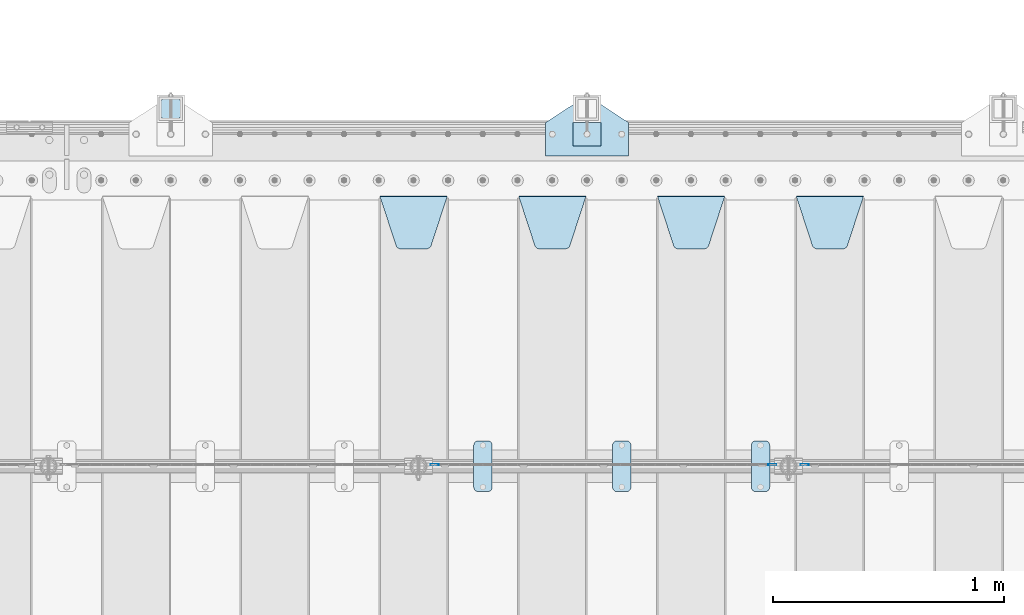
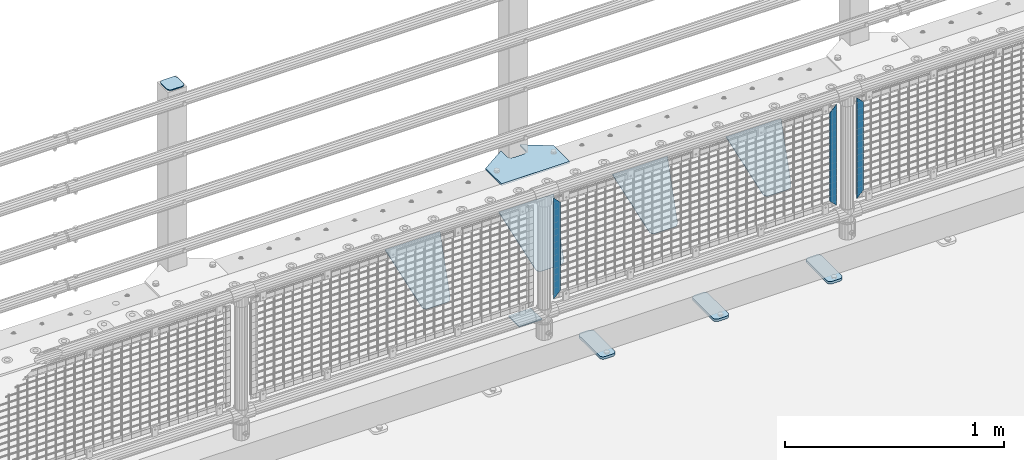
# One storey, part 217 of 247: 13 plates.
"""IFC2X3 building model written with IfcOpenShell, lengths in millimetres."""

from ifc_helpers import new_model, si_unit, frame, origin_with_axes, place, context, subcontext, project, spatial, faceted_brep, material, type_object, element, save


model = new_model("IFC2X3")

# Units and contexts
model_context = context("Model", 3, precision=1e-05, world=origin_with_axes())
body_context = subcontext(model_context, "Body", "Model", "MODEL_VIEW")
ifc_project = project(units=[si_unit("LENGTHUNIT", "METRE", prefix="MILLI"), si_unit("AREAUNIT", "SQUARE_METRE"), si_unit("VOLUMEUNIT", "CUBIC_METRE"), si_unit("MASSUNIT", "GRAM", prefix="KILO"), si_unit("TIMEUNIT", "SECOND"), si_unit("PLANEANGLEUNIT", "RADIAN"), si_unit("SOLIDANGLEUNIT", "STERADIAN"), si_unit("THERMODYNAMICTEMPERATUREUNIT", "DEGREE_CELSIUS"), si_unit("LUMINOUSINTENSITYUNIT", "LUMEN")], contexts=[model_context])

# Site, building, storey
site_placement = place(None, origin_with_axes())
site = spatial("IfcSite", under=ifc_project, at=site_placement, CompositionType="ELEMENT")
building_placement = place(site_placement, origin_with_axes())
building = spatial("IfcBuilding", under=site, at=building_placement, Name="Standard", CompositionType="ELEMENT")
storey_placement = place(building_placement, origin_with_axes())
storey = spatial("IfcBuildingStorey", under=building, at=storey_placement, Name="Undefined", CompositionType="ELEMENT", Elevation=0.0)

# Plates
ifc_material_1 = material(Name="STEEL/S355J2")
plate_type_1 = type_object("IfcPlateType", PredefinedType="NOTDEFINED")
plate_1_placement = place(storey_placement, frame((8460.0, 7774.5, 21.0199999999977), z_axis=(1.0, 0.0, 0.0), x_axis=(0.0, -0.999999999999548, -9.5100000000016e-07)))
element("IfcPlate", 1, at=plate_1_placement, inside=storey, type_object=plate_type_1, material=ifc_material_1, context=body_context, shape_type="Brep", body=[
    faceted_brep([(0.0, -7.0, 20.0), (0.0, -7.0, 60.0), (0.0, 7.0, 60.0), (0.0, 7.0, 20.0), (0.384294391935327, -7.0, 63.9018064403226), (0.384294391935327, 7.0, 63.9018064403226), (1.52240934977453, -7.0, 67.6536686473009), (1.52240934977453, 7.0, 67.6536686473009), (3.37060775394912, -7.0, 71.1114046603925), (3.37060775394912, 7.0, 71.1114046603925), (5.85786437626939, -7.0, 74.1421356237315), (5.85786437626939, 7.0, 74.1421356237315), (8.8885953396084, -7.0, 76.6293922460518), (8.8885953396084, 7.0, 76.6293922460518), (12.3463313526981, -7.0, 78.4775906502255), (12.3463313526981, 7.0, 78.4775906502255), (16.0981935596774, -7.0, 79.6157056080647), (16.0981935596774, 7.0, 79.6157056080647), (20.0, -7.0, 80.0), (20.0, 7.0, 80.0), (200.0, -7.0, 80.0), (200.0, 7.0, 80.0), (203.901806440323, -7.0, 79.6157056080647), (203.901806440323, 7.0, 79.6157056080647), (207.653668647302, -7.0, 78.4775906502255), (207.653668647302, 7.0, 78.4775906502255), (211.111404660392, -7.0, 76.6293922460518), (211.111404660392, 7.0, 76.6293922460518), (214.142135623731, -7.0, 74.1421356237315), (214.142135623731, 7.0, 74.1421356237315), (216.629392246051, -7.0, 71.1114046603925), (216.629392246051, 7.0, 71.1114046603925), (218.477590650225, -7.0, 67.6536686473009), (218.477590650225, 7.0, 67.6536686473009), (219.615705608065, -7.0, 63.9018064403226), (219.615705608065, 7.0, 63.9018064403226), (220.0, -7.0, 60.0), (220.0, 7.0, 60.0), (220.0, -7.0, 20.0), (220.0, 7.0, 20.0), (219.615705608065, -7.0, 16.0981935596774), (219.615705608065, 7.0, 16.0981935596774), (218.477590650225, -7.0, 12.3463313526991), (218.477590650225, 7.0, 12.3463313526991), (216.629392246051, -7.0, 8.88859533960749), (216.629392246051, 7.0, 8.88859533960749), (214.142135623731, -7.0, 5.85786437626848), (214.142135623731, 7.0, 5.85786437626848), (211.111404660392, -7.0, 3.37060775394821), (211.111404660392, 7.0, 3.37060775394821), (207.653668647302, -7.0, 1.52240934977453), (207.653668647302, 7.0, 1.52240934977453), (203.901806440323, -7.0, 0.384294391935327), (203.901806440323, 7.0, 0.384294391935327), (200.0, -7.0, 0.0), (200.0, 7.0, 0.0), (20.0, -7.0, 0.0), (20.0, 7.0, 0.0), (16.0981935596774, -7.0, 0.384294391935327), (16.0981935596774, 7.0, 0.384294391935327), (12.3463313526981, -7.0, 1.52240934977453), (12.3463313526981, 7.0, 1.52240934977453), (8.8885953396084, -7.0, 3.37060775394821), (8.8885953396084, 7.0, 3.37060775394821), (5.85786437626939, -7.0, 5.85786437626848), (5.85786437626939, 7.0, 5.85786437626848), (3.37060775394912, -7.0, 8.88859533960749), (3.37060775394912, 7.0, 8.88859533960749), (1.52240934977453, -7.0, 12.3463313526991), (1.52240934977453, 7.0, 12.3463313526991), (0.384294391935327, -7.0, 16.0981935596774), (0.384294391935327, 7.0, 16.0981935596774)], [[[0, 1, 2, 3]], [[1, 4, 5, 2]], [[4, 6, 7, 5]], [[6, 8, 9, 7]], [[8, 10, 11, 9]], [[10, 12, 13, 11]], [[12, 14, 15, 13]], [[14, 16, 17, 15]], [[16, 18, 19, 17]], [[18, 20, 21, 19]], [[20, 22, 23, 21]], [[22, 24, 25, 23]], [[24, 26, 27, 25]], [[26, 28, 29, 27]], [[28, 30, 31, 29]], [[30, 32, 33, 31]], [[32, 34, 35, 33]], [[34, 36, 37, 35]], [[36, 38, 39, 37]], [[38, 40, 41, 39]], [[40, 42, 43, 41]], [[42, 44, 45, 43]], [[44, 46, 47, 45]], [[46, 48, 49, 47]], [[48, 50, 51, 49]], [[50, 52, 53, 51]], [[52, 54, 55, 53]], [[54, 56, 57, 55]], [[56, 58, 59, 57]], [[58, 60, 61, 59]], [[60, 62, 63, 61]], [[62, 64, 65, 63]], [[64, 66, 67, 65]], [[66, 68, 69, 67]], [[68, 70, 71, 69]], [[70, 0, 3, 71]], [[5, 7, 9, 11, 13, 15, 17, 19, 21, 23, 25, 27, 29, 31, 33, 35, 37, 39, 41, 43, 45, 47, 49, 51, 53, 55, 57, 59, 61, 63, 65, 67, 69, 71, 3, 2]], [[70, 68, 66, 64, 62, 60, 58, 56, 54, 52, 50, 48, 46, 44, 42, 40, 38, 36, 34, 32, 30, 28, 26, 24, 22, 20, 18, 16, 14, 12, 10, 8, 6, 4, 1, 0]]]),
])
plate_2_placement = place(storey_placement, frame((7860.0, 7774.5, 21.0199999999977), z_axis=(1.0, 0.0, 0.0), x_axis=(0.0, -0.999999999999548, -9.5100000000016e-07)))
element("IfcPlate", 2, at=plate_2_placement, inside=storey, type_object=plate_type_1, material=ifc_material_1, context=body_context, shape_type="Brep", body=[
    faceted_brep([(0.0, -7.0, 20.0), (0.0, -7.0, 60.0), (0.0, 7.0, 60.0), (0.0, 7.0, 20.0), (0.384294391935327, -7.0, 63.9018064403226), (0.384294391935327, 7.0, 63.9018064403226), (1.52240934977453, -7.0, 67.6536686473009), (1.52240934977453, 7.0, 67.6536686473009), (3.37060775394912, -7.0, 71.1114046603925), (3.37060775394912, 7.0, 71.1114046603925), (5.85786437626939, -7.0, 74.1421356237315), (5.85786437626939, 7.0, 74.1421356237315), (8.8885953396084, -7.0, 76.6293922460518), (8.8885953396084, 7.0, 76.6293922460518), (12.3463313526981, -7.0, 78.4775906502255), (12.3463313526981, 7.0, 78.4775906502255), (16.0981935596774, -7.0, 79.6157056080647), (16.0981935596774, 7.0, 79.6157056080647), (20.0, -7.0, 80.0), (20.0, 7.0, 80.0), (200.0, -7.0, 80.0), (200.0, 7.0, 80.0), (203.901806440323, -7.0, 79.6157056080647), (203.901806440323, 7.0, 79.6157056080647), (207.653668647302, -7.0, 78.4775906502255), (207.653668647302, 7.0, 78.4775906502255), (211.111404660392, -7.0, 76.6293922460518), (211.111404660392, 7.0, 76.6293922460518), (214.142135623731, -7.0, 74.1421356237315), (214.142135623731, 7.0, 74.1421356237315), (216.629392246051, -7.0, 71.1114046603925), (216.629392246051, 7.0, 71.1114046603925), (218.477590650225, -7.0, 67.6536686473009), (218.477590650225, 7.0, 67.6536686473009), (219.615705608065, -7.0, 63.9018064403226), (219.615705608065, 7.0, 63.9018064403226), (220.0, -7.0, 60.0), (220.0, 7.0, 60.0), (220.0, -7.0, 20.0), (220.0, 7.0, 20.0), (219.615705608065, -7.0, 16.0981935596774), (219.615705608065, 7.0, 16.0981935596774), (218.477590650225, -7.0, 12.3463313526991), (218.477590650225, 7.0, 12.3463313526991), (216.629392246051, -7.0, 8.88859533960749), (216.629392246051, 7.0, 8.88859533960749), (214.142135623731, -7.0, 5.85786437626848), (214.142135623731, 7.0, 5.85786437626848), (211.111404660392, -7.0, 3.37060775394821), (211.111404660392, 7.0, 3.37060775394821), (207.653668647302, -7.0, 1.52240934977453), (207.653668647302, 7.0, 1.52240934977453), (203.901806440323, -7.0, 0.384294391935327), (203.901806440323, 7.0, 0.384294391935327), (200.0, -7.0, 0.0), (200.0, 7.0, 0.0), (20.0, -7.0, 0.0), (20.0, 7.0, 0.0), (16.0981935596774, -7.0, 0.384294391935327), (16.0981935596774, 7.0, 0.384294391935327), (12.3463313526981, -7.0, 1.52240934977453), (12.3463313526981, 7.0, 1.52240934977453), (8.8885953396084, -7.0, 3.37060775394821), (8.8885953396084, 7.0, 3.37060775394821), (5.85786437626939, -7.0, 5.85786437626848), (5.85786437626939, 7.0, 5.85786437626848), (3.37060775394912, -7.0, 8.88859533960749), (3.37060775394912, 7.0, 8.88859533960749), (1.52240934977453, -7.0, 12.3463313526991), (1.52240934977453, 7.0, 12.3463313526991), (0.384294391935327, -7.0, 16.0981935596774), (0.384294391935327, 7.0, 16.0981935596774)], [[[0, 1, 2, 3]], [[1, 4, 5, 2]], [[4, 6, 7, 5]], [[6, 8, 9, 7]], [[8, 10, 11, 9]], [[10, 12, 13, 11]], [[12, 14, 15, 13]], [[14, 16, 17, 15]], [[16, 18, 19, 17]], [[18, 20, 21, 19]], [[20, 22, 23, 21]], [[22, 24, 25, 23]], [[24, 26, 27, 25]], [[26, 28, 29, 27]], [[28, 30, 31, 29]], [[30, 32, 33, 31]], [[32, 34, 35, 33]], [[34, 36, 37, 35]], [[36, 38, 39, 37]], [[38, 40, 41, 39]], [[40, 42, 43, 41]], [[42, 44, 45, 43]], [[44, 46, 47, 45]], [[46, 48, 49, 47]], [[48, 50, 51, 49]], [[50, 52, 53, 51]], [[52, 54, 55, 53]], [[54, 56, 57, 55]], [[56, 58, 59, 57]], [[58, 60, 61, 59]], [[60, 62, 63, 61]], [[62, 64, 65, 63]], [[64, 66, 67, 65]], [[66, 68, 69, 67]], [[68, 70, 71, 69]], [[70, 0, 3, 71]], [[5, 7, 9, 11, 13, 15, 17, 19, 21, 23, 25, 27, 29, 31, 33, 35, 37, 39, 41, 43, 45, 47, 49, 51, 53, 55, 57, 59, 61, 63, 65, 67, 69, 71, 3, 2]], [[70, 68, 66, 64, 62, 60, 58, 56, 54, 52, 50, 48, 46, 44, 42, 40, 38, 36, 34, 32, 30, 28, 26, 24, 22, 20, 18, 16, 14, 12, 10, 8, 6, 4, 1, 0]]]),
])
plate_3_placement = place(storey_placement, frame((7260.0, 7774.5, 21.0199999999977), z_axis=(1.0, 0.0, 0.0), x_axis=(0.0, -0.999999999999548, -9.5100000000016e-07)))
element("IfcPlate", 3, at=plate_3_placement, inside=storey, type_object=plate_type_1, material=ifc_material_1, context=body_context, shape_type="Brep", body=[
    faceted_brep([(0.0, -7.0, 20.0), (0.0, -7.0, 60.0), (0.0, 7.0, 60.0), (0.0, 7.0, 20.0), (0.384294391935327, -7.0, 63.9018064403226), (0.384294391935327, 7.0, 63.9018064403226), (1.52240934977453, -7.0, 67.6536686473009), (1.52240934977453, 7.0, 67.6536686473009), (3.37060775394912, -7.0, 71.1114046603925), (3.37060775394912, 7.0, 71.1114046603925), (5.85786437626939, -7.0, 74.1421356237315), (5.85786437626939, 7.0, 74.1421356237315), (8.8885953396084, -7.0, 76.6293922460518), (8.8885953396084, 7.0, 76.6293922460518), (12.3463313526981, -7.0, 78.4775906502255), (12.3463313526981, 7.0, 78.4775906502255), (16.0981935596774, -7.0, 79.6157056080647), (16.0981935596774, 7.0, 79.6157056080647), (20.0, -7.0, 80.0), (20.0, 7.0, 80.0), (200.0, -7.0, 80.0), (200.0, 7.0, 80.0), (203.901806440323, -7.0, 79.6157056080647), (203.901806440323, 7.0, 79.6157056080647), (207.653668647302, -7.0, 78.4775906502255), (207.653668647302, 7.0, 78.4775906502255), (211.111404660392, -7.0, 76.6293922460518), (211.111404660392, 7.0, 76.6293922460518), (214.142135623731, -7.0, 74.1421356237315), (214.142135623731, 7.0, 74.1421356237315), (216.629392246051, -7.0, 71.1114046603925), (216.629392246051, 7.0, 71.1114046603925), (218.477590650225, -7.0, 67.6536686473009), (218.477590650225, 7.0, 67.6536686473009), (219.615705608065, -7.0, 63.9018064403226), (219.615705608065, 7.0, 63.9018064403226), (220.0, -7.0, 60.0), (220.0, 7.0, 60.0), (220.0, -7.0, 20.0), (220.0, 7.0, 20.0), (219.615705608065, -7.0, 16.0981935596774), (219.615705608065, 7.0, 16.0981935596774), (218.477590650225, -7.0, 12.3463313526991), (218.477590650225, 7.0, 12.3463313526991), (216.629392246051, -7.0, 8.88859533960749), (216.629392246051, 7.0, 8.88859533960749), (214.142135623731, -7.0, 5.85786437626848), (214.142135623731, 7.0, 5.85786437626848), (211.111404660392, -7.0, 3.37060775394821), (211.111404660392, 7.0, 3.37060775394821), (207.653668647302, -7.0, 1.52240934977453), (207.653668647302, 7.0, 1.52240934977453), (203.901806440323, -7.0, 0.384294391935327), (203.901806440323, 7.0, 0.384294391935327), (200.0, -7.0, 0.0), (200.0, 7.0, 0.0), (20.0, -7.0, 0.0), (20.0, 7.0, 0.0), (16.0981935596774, -7.0, 0.384294391935327), (16.0981935596774, 7.0, 0.384294391935327), (12.3463313526981, -7.0, 1.52240934977453), (12.3463313526981, 7.0, 1.52240934977453), (8.8885953396084, -7.0, 3.37060775394821), (8.8885953396084, 7.0, 3.37060775394821), (5.85786437626939, -7.0, 5.85786437626848), (5.85786437626939, 7.0, 5.85786437626848), (3.37060775394912, -7.0, 8.88859533960749), (3.37060775394912, 7.0, 8.88859533960749), (1.52240934977453, -7.0, 12.3463313526991), (1.52240934977453, 7.0, 12.3463313526991), (0.384294391935327, -7.0, 16.0981935596774), (0.384294391935327, 7.0, 16.0981935596774)], [[[0, 1, 2, 3]], [[1, 4, 5, 2]], [[4, 6, 7, 5]], [[6, 8, 9, 7]], [[8, 10, 11, 9]], [[10, 12, 13, 11]], [[12, 14, 15, 13]], [[14, 16, 17, 15]], [[16, 18, 19, 17]], [[18, 20, 21, 19]], [[20, 22, 23, 21]], [[22, 24, 25, 23]], [[24, 26, 27, 25]], [[26, 28, 29, 27]], [[28, 30, 31, 29]], [[30, 32, 33, 31]], [[32, 34, 35, 33]], [[34, 36, 37, 35]], [[36, 38, 39, 37]], [[38, 40, 41, 39]], [[40, 42, 43, 41]], [[42, 44, 45, 43]], [[44, 46, 47, 45]], [[46, 48, 49, 47]], [[48, 50, 51, 49]], [[50, 52, 53, 51]], [[52, 54, 55, 53]], [[54, 56, 57, 55]], [[56, 58, 59, 57]], [[58, 60, 61, 59]], [[60, 62, 63, 61]], [[62, 64, 65, 63]], [[64, 66, 67, 65]], [[66, 68, 69, 67]], [[68, 70, 71, 69]], [[70, 0, 3, 71]], [[5, 7, 9, 11, 13, 15, 17, 19, 21, 23, 25, 27, 29, 31, 33, 35, 37, 39, 41, 43, 45, 47, 49, 51, 53, 55, 57, 59, 61, 63, 65, 67, 69, 71, 3, 2]], [[70, 68, 66, 64, 62, 60, 58, 56, 54, 52, 50, 48, 46, 44, 42, 40, 38, 36, 34, 32, 30, 28, 26, 24, 22, 20, 18, 16, 14, 12, 10, 8, 6, 4, 1, 0]]]),
])
ifc_material_2 = material(Name="STEEL/S355N")
plate_type_2 = type_object("IfcPlateType", PredefinedType="NOTDEFINED")
plate_4_placement = place(storey_placement, frame((8655.0, 8831.76776695594, -1.767766952965), z_axis=(0.0, -0.707106781186548, -0.707106781186547), x_axis=(1.0, 0.0, 0.0)))
element("IfcPlate", 4, at=plate_4_placement, inside=storey, type_object=plate_type_2, material=ifc_material_2, context=body_context, shape_type="Brep", body=[
    faceted_brep([(0.0, -2.49999999999909, 0.0), (69.345504679477, -2.5, 300.17173142483), (69.345504679477, 2.50000000000091, 300.171731424831), (0.0, 2.5, -9.09494701772928e-13), (70.9274061199576, -2.5, 304.897442415399), (70.9274061199576, 2.50000000000091, 304.8974424154), (73.3818627772307, -2.49999999999909, 309.234538108527), (73.3818627772307, 2.5, 309.234538108526), (76.6187032999551, -2.5, 313.023683126102), (76.6187032999551, 2.50000000000091, 313.023683126102), (80.5190132704993, -2.49999999999909, 316.125672595371), (80.5190132704993, 2.50000000000091, 316.125672595372), (84.9395038596849, -2.49999999999909, 318.426546230476), (84.9395038596849, 2.5, 318.426546230475), (89.7177759439219, -2.5, 319.841774983274), (89.7177759439219, 2.50000000000091, 319.841774983275), (94.678286292652, -2.5, 320.319366455077), (94.678286292652, 2.50000000000091, 320.319366455077), (195.321713707348, -2.5, 320.319366455077), (195.321713707348, 2.50000000000091, 320.319366455077), (200.282224056078, -2.5, 319.841774983274), (200.282224056078, 2.50000000000091, 319.841774983275), (205.060496140315, -2.5, 318.426546230475), (205.060496140315, 2.5, 318.426546230474), (209.480986729501, -2.49999999999818, 316.12567259537), (209.480986729501, 2.50000000000091, 316.12567259537), (213.381296700045, -2.5, 313.023683126101), (213.381296700045, 2.50000000000091, 313.023683126101), (216.618137222769, -2.5, 309.234538108525), (216.618137222769, 2.5, 309.234538108525), (219.072593880042, -2.49999999999909, 304.897442415398), (219.072593880042, 2.5, 304.897442415398), (220.654495320523, -2.5, 300.17173142483), (220.654495320523, 2.50000000000091, 300.171731424831), (290.0, -2.49999999999909, 0.0), (290.0, 2.5, -9.09494701772928e-13)], [[[0, 1, 2, 3]], [[1, 4, 5, 2]], [[4, 6, 7, 5]], [[6, 8, 9, 7]], [[8, 10, 11, 9]], [[10, 12, 13, 11]], [[12, 14, 15, 13]], [[14, 16, 17, 15]], [[16, 18, 19, 17]], [[18, 20, 21, 19]], [[20, 22, 23, 21]], [[22, 24, 25, 23]], [[24, 26, 27, 25]], [[26, 28, 29, 27]], [[28, 30, 31, 29]], [[30, 32, 33, 31]], [[32, 34, 35, 33]], [[34, 0, 3, 35]], [[5, 7, 9, 11, 13, 15, 17, 19, 21, 23, 25, 27, 29, 31, 33, 35, 3, 2]], [[34, 32, 30, 28, 26, 24, 22, 20, 18, 16, 14, 12, 10, 8, 6, 4, 1, 0]]]),
])
plate_5_placement = place(storey_placement, frame((8055.0, 8831.76776695594, -1.767766952965), z_axis=(0.0, -0.707106781186548, -0.707106781186547), x_axis=(1.0, 0.0, 0.0)))
element("IfcPlate", 5, at=plate_5_placement, inside=storey, type_object=plate_type_2, material=ifc_material_2, context=body_context, shape_type="Brep", body=[
    faceted_brep([(0.0, -2.49999999999909, 0.0), (69.345504679477, -2.5, 300.17173142483), (69.345504679477, 2.50000000000091, 300.171731424831), (0.0, 2.5, -9.09494701772928e-13), (70.9274061199576, -2.5, 304.897442415399), (70.9274061199576, 2.50000000000091, 304.8974424154), (73.3818627772307, -2.49999999999909, 309.234538108527), (73.3818627772307, 2.5, 309.234538108526), (76.6187032999551, -2.5, 313.023683126102), (76.6187032999551, 2.50000000000091, 313.023683126102), (80.5190132704993, -2.49999999999909, 316.125672595371), (80.5190132704993, 2.50000000000091, 316.125672595372), (84.9395038596849, -2.49999999999909, 318.426546230476), (84.9395038596849, 2.5, 318.426546230475), (89.7177759439219, -2.5, 319.841774983274), (89.7177759439219, 2.50000000000091, 319.841774983275), (94.678286292652, -2.5, 320.319366455077), (94.678286292652, 2.50000000000091, 320.319366455077), (195.321713707348, -2.5, 320.319366455077), (195.321713707348, 2.50000000000091, 320.319366455077), (200.282224056078, -2.5, 319.841774983274), (200.282224056078, 2.50000000000091, 319.841774983275), (205.060496140315, -2.5, 318.426546230475), (205.060496140315, 2.5, 318.426546230474), (209.480986729501, -2.49999999999818, 316.12567259537), (209.480986729501, 2.50000000000091, 316.12567259537), (213.381296700045, -2.5, 313.023683126101), (213.381296700045, 2.50000000000091, 313.023683126101), (216.618137222769, -2.5, 309.234538108525), (216.618137222769, 2.5, 309.234538108525), (219.072593880042, -2.49999999999909, 304.897442415398), (219.072593880042, 2.5, 304.897442415398), (220.654495320523, -2.5, 300.17173142483), (220.654495320523, 2.50000000000091, 300.171731424831), (290.0, -2.49999999999909, 0.0), (290.0, 2.5, -9.09494701772928e-13)], [[[0, 1, 2, 3]], [[1, 4, 5, 2]], [[4, 6, 7, 5]], [[6, 8, 9, 7]], [[8, 10, 11, 9]], [[10, 12, 13, 11]], [[12, 14, 15, 13]], [[14, 16, 17, 15]], [[16, 18, 19, 17]], [[18, 20, 21, 19]], [[20, 22, 23, 21]], [[22, 24, 25, 23]], [[24, 26, 27, 25]], [[26, 28, 29, 27]], [[28, 30, 31, 29]], [[30, 32, 33, 31]], [[32, 34, 35, 33]], [[34, 0, 3, 35]], [[5, 7, 9, 11, 13, 15, 17, 19, 21, 23, 25, 27, 29, 31, 33, 35, 3, 2]], [[34, 32, 30, 28, 26, 24, 22, 20, 18, 16, 14, 12, 10, 8, 6, 4, 1, 0]]]),
])
plate_6_placement = place(storey_placement, frame((7455.0, 8831.76776695594, -1.767766952965), z_axis=(0.0, -0.707106781186548, -0.707106781186547), x_axis=(1.0, 0.0, 0.0)))
element("IfcPlate", 6, at=plate_6_placement, inside=storey, type_object=plate_type_2, material=ifc_material_2, context=body_context, shape_type="Brep", body=[
    faceted_brep([(0.0, -2.49999999999909, 0.0), (69.345504679477, -2.5, 300.17173142483), (69.345504679477, 2.50000000000091, 300.171731424831), (0.0, 2.5, -9.09494701772928e-13), (70.9274061199576, -2.5, 304.897442415399), (70.9274061199576, 2.50000000000091, 304.8974424154), (73.3818627772307, -2.49999999999909, 309.234538108527), (73.3818627772307, 2.5, 309.234538108526), (76.6187032999551, -2.5, 313.023683126102), (76.6187032999551, 2.50000000000091, 313.023683126102), (80.5190132704993, -2.49999999999909, 316.125672595371), (80.5190132704993, 2.50000000000091, 316.125672595372), (84.9395038596849, -2.49999999999909, 318.426546230476), (84.9395038596849, 2.5, 318.426546230475), (89.7177759439219, -2.5, 319.841774983274), (89.7177759439219, 2.50000000000091, 319.841774983275), (94.678286292652, -2.5, 320.319366455077), (94.678286292652, 2.50000000000091, 320.319366455077), (195.321713707348, -2.5, 320.319366455077), (195.321713707348, 2.50000000000091, 320.319366455077), (200.282224056078, -2.5, 319.841774983274), (200.282224056078, 2.50000000000091, 319.841774983275), (205.060496140315, -2.5, 318.426546230475), (205.060496140315, 2.5, 318.426546230474), (209.480986729501, -2.49999999999818, 316.12567259537), (209.480986729501, 2.50000000000091, 316.12567259537), (213.381296700045, -2.5, 313.023683126101), (213.381296700045, 2.50000000000091, 313.023683126101), (216.618137222769, -2.5, 309.234538108525), (216.618137222769, 2.5, 309.234538108525), (219.072593880042, -2.49999999999909, 304.897442415398), (219.072593880042, 2.5, 304.897442415398), (220.654495320523, -2.5, 300.17173142483), (220.654495320523, 2.50000000000091, 300.171731424831), (290.0, -2.49999999999909, 0.0), (290.0, 2.5, -9.09494701772928e-13)], [[[0, 1, 2, 3]], [[1, 4, 5, 2]], [[4, 6, 7, 5]], [[6, 8, 9, 7]], [[8, 10, 11, 9]], [[10, 12, 13, 11]], [[12, 14, 15, 13]], [[14, 16, 17, 15]], [[16, 18, 19, 17]], [[18, 20, 21, 19]], [[20, 22, 23, 21]], [[22, 24, 25, 23]], [[24, 26, 27, 25]], [[26, 28, 29, 27]], [[28, 30, 31, 29]], [[30, 32, 33, 31]], [[32, 34, 35, 33]], [[34, 0, 3, 35]], [[5, 7, 9, 11, 13, 15, 17, 19, 21, 23, 25, 27, 29, 31, 33, 35, 3, 2]], [[34, 32, 30, 28, 26, 24, 22, 20, 18, 16, 14, 12, 10, 8, 6, 4, 1, 0]]]),
])
plate_7_placement = place(storey_placement, frame((6855.0, 8831.76776695594, -1.767766952965), z_axis=(0.0, -0.707106781186548, -0.707106781186547), x_axis=(1.0, 0.0, 0.0)))
element("IfcPlate", 7, at=plate_7_placement, inside=storey, type_object=plate_type_2, material=ifc_material_2, context=body_context, shape_type="Brep", body=[
    faceted_brep([(0.0, -2.49999999999909, 0.0), (69.345504679477, -2.5, 300.17173142483), (69.345504679477, 2.50000000000091, 300.171731424831), (0.0, 2.5, -9.09494701772928e-13), (70.9274061199576, -2.5, 304.897442415399), (70.9274061199576, 2.50000000000091, 304.8974424154), (73.3818627772307, -2.49999999999909, 309.234538108527), (73.3818627772307, 2.5, 309.234538108526), (76.6187032999551, -2.5, 313.023683126102), (76.6187032999551, 2.50000000000091, 313.023683126102), (80.5190132704993, -2.49999999999909, 316.125672595371), (80.5190132704993, 2.50000000000091, 316.125672595372), (84.9395038596849, -2.49999999999909, 318.426546230476), (84.9395038596849, 2.5, 318.426546230475), (89.7177759439219, -2.5, 319.841774983274), (89.7177759439219, 2.50000000000091, 319.841774983275), (94.678286292652, -2.5, 320.319366455077), (94.678286292652, 2.50000000000091, 320.319366455077), (195.321713707348, -2.5, 320.319366455077), (195.321713707348, 2.50000000000091, 320.319366455077), (200.282224056078, -2.5, 319.841774983274), (200.282224056078, 2.50000000000091, 319.841774983275), (205.060496140315, -2.5, 318.426546230475), (205.060496140315, 2.5, 318.426546230474), (209.480986729501, -2.49999999999818, 316.12567259537), (209.480986729501, 2.50000000000091, 316.12567259537), (213.381296700045, -2.5, 313.023683126101), (213.381296700045, 2.50000000000091, 313.023683126101), (216.618137222769, -2.5, 309.234538108525), (216.618137222769, 2.5, 309.234538108525), (219.072593880042, -2.49999999999909, 304.897442415398), (219.072593880042, 2.5, 304.897442415398), (220.654495320523, -2.5, 300.17173142483), (220.654495320523, 2.50000000000091, 300.171731424831), (290.0, -2.49999999999909, 0.0), (290.0, 2.5, -9.09494701772928e-13)], [[[0, 1, 2, 3]], [[1, 4, 5, 2]], [[4, 6, 7, 5]], [[6, 8, 9, 7]], [[8, 10, 11, 9]], [[10, 12, 13, 11]], [[12, 14, 15, 13]], [[14, 16, 17, 15]], [[16, 18, 19, 17]], [[18, 20, 21, 19]], [[20, 22, 23, 21]], [[22, 24, 25, 23]], [[24, 26, 27, 25]], [[26, 28, 29, 27]], [[28, 30, 31, 29]], [[30, 32, 33, 31]], [[32, 34, 35, 33]], [[34, 0, 3, 35]], [[5, 7, 9, 11, 13, 15, 17, 19, 21, 23, 25, 27, 29, 31, 33, 35, 3, 2]], [[34, 32, 30, 28, 26, 24, 22, 20, 18, 16, 14, 12, 10, 8, 6, 4, 1, 0]]]),
])
ifc_material_3 = material(Name="Misc_Undefined")
plate_type_3 = type_object("IfcPlateType", PredefinedType="NOTDEFINED")
for number, where, z_axis, x_axis in (
    (8, (8709.50971354097, 7670.5, 879.519963133601), (-0.707008801899319, 0.0, -0.707204746899291), (-0.707204746899294, 0.0, 0.707008801899315)),
    (9, (7109.50971354097, 7670.5, 879.519963133601), (-0.707008801899319, 0.0, -0.707204746899291), (-0.707204746899294, 0.0, 0.707008801899315)),
):
    element("IfcPlate", number, at=place(storey_placement, frame(where, z_axis=z_axis, x_axis=x_axis)), inside=storey, type_object=plate_type_3, material=ifc_material_3, context=body_context, shape_type="Brep", body=[
        faceted_brep([(1.81898940354586e-12, -1.5, -5.6843418860808e-14), (-348.552185058596, -1.5, 348.655029296875), (-348.552185058596, 1.5, 348.655029296875), (1.81898940354586e-12, 1.5, -5.6843418860808e-14), (-348.544891357424, -1.5, 398.152496337891), (-348.544891357424, 1.5, 398.152496337891), (49.50439453125, -1.5, 7.6397554948926e-11), (49.50439453125, 1.5, 7.6397554948926e-11)], [[[0, 1, 2, 3]], [[1, 4, 5, 2]], [[4, 6, 7, 5]], [[6, 0, 3, 7]], [[5, 7, 3, 2]], [[6, 4, 1, 0]]]),
    ])
plate_8_placement = place(storey_placement, frame((8532.49968748361, 7670.5, 879.52), z_axis=(0.707103624179499, 0.0, -0.707109938179501), x_axis=(0.707109938179497, 0.0, 0.707103624179503)))
element("IfcPlate", 10, at=plate_8_placement, inside=storey, type_object=plate_type_3, material=ifc_material_3, context=body_context, shape_type="Brep", body=[
    faceted_brep([(1.81898940354586e-12, -1.5, -5.6843418860808e-14), (-348.605163574215, -1.5, 348.60208129883), (-348.605163574215, 1.5, 348.60208129883), (1.81898940354586e-12, 1.5, -5.6843418860808e-14), (-348.605163574215, -1.5, 398.099334716799), (-348.605163574215, 1.5, 398.099334716799), (49.4976959228497, -1.5, 7.09405867382884e-11), (49.4976959228497, 1.5, 7.09405867382884e-11)], [[[0, 1, 2, 3]], [[1, 4, 5, 2]], [[4, 6, 7, 5]], [[6, 0, 3, 7]], [[5, 7, 3, 2]], [[6, 4, 1, 0]]]),
])
plate_type_4 = type_object("IfcPlateType", PredefinedType="NOTDEFINED")
plate_9_placement = place(storey_placement, frame((7570.0, 9005.0, 5.00000000004911), z_axis=(0.0, 1.0, 0.0), x_axis=(1.0, 0.0, 0.0)))
element("IfcPlate", 11, at=plate_9_placement, inside=storey, type_object=plate_type_4, material=ifc_material_1, context=body_context, shape_type="Brep", body=[
    faceted_brep([(9.04219632502645e-09, -5.00000000143385, -2.89173840428703e-09), (2.31396552408114e-06, -5.0, 145.0), (2.31396552408114e-06, 5.0, 145.0), (7.66340235713869e-09, 4.99999999856618, -2.89173840428703e-09), (130.0, -5.0, 230.0), (130.0, 5.0, 230.0), (130.0, -5.0, 180.0), (130.0, 5.0, 180.0), (130.48036798992, -5.0, 175.122741949597), (130.48036798992, 5.0, 175.122741949597), (131.903011687218, -5.0, 170.432914190873), (131.903011687218, 5.0, 170.432914190873), (134.213259692437, -5.0, 166.11074417451), (134.213259692437, 5.0, 166.11074417451), (137.322330470337, -5.0, 162.322330470337), (137.322330470337, 5.0, 162.322330470337), (141.11074417451, -5.0, 159.213259692437), (141.11074417451, 5.0, 159.213259692437), (145.432914190873, -5.0, 156.903011687218), (145.432914190873, 5.0, 156.903011687218), (150.122741949597, -5.0, 155.48036798992), (150.122741949597, 5.0, 155.48036798992), (155.0, -5.0, 155.0), (155.0, 5.0, 155.0), (205.0, -5.0, 155.0), (205.0, 5.0, 155.0), (209.877258050403, -5.0, 155.48036798992), (209.877258050403, 5.0, 155.48036798992), (214.567085809127, -5.0, 156.903011687218), (214.567085809127, 5.0, 156.903011687218), (218.88925582549, -5.0, 159.213259692437), (218.88925582549, 5.0, 159.213259692437), (222.677669529663, -5.0, 162.322330470337), (222.677669529663, 5.0, 162.322330470337), (225.786740307563, -5.0, 166.11074417451), (225.786740307563, 5.0, 166.11074417451), (228.096988312782, -5.0, 170.432914190873), (228.096988312782, 5.0, 170.432914190873), (229.51963201008, -5.0, 175.122741949597), (229.51963201008, 5.0, 175.122741949597), (230.0, -5.0, 180.0), (230.0, 5.0, 180.0), (230.0, -5.0, 230.0), (230.0, 5.0, 230.0), (360.0, -5.0, 145.0), (360.0, 5.0, 145.0), (360.0, -5.0, -7.27595761418343e-12), (360.0, 5.0, -7.27595761418343e-12)], [[[0, 1, 2, 3]], [[1, 4, 5, 2]], [[4, 6, 7, 5]], [[6, 8, 9, 7]], [[8, 10, 11, 9]], [[10, 12, 13, 11]], [[12, 14, 15, 13]], [[14, 16, 17, 15]], [[16, 18, 19, 17]], [[18, 20, 21, 19]], [[20, 22, 23, 21]], [[22, 24, 25, 23]], [[24, 26, 27, 25]], [[26, 28, 29, 27]], [[28, 30, 31, 29]], [[30, 32, 33, 31]], [[32, 34, 35, 33]], [[34, 36, 37, 35]], [[36, 38, 39, 37]], [[38, 40, 41, 39]], [[40, 42, 43, 41]], [[42, 44, 45, 43]], [[44, 46, 47, 45]], [[46, 0, 3, 47]], [[5, 7, 9, 11, 13, 15, 17, 19, 21, 23, 25, 27, 29, 31, 33, 35, 37, 39, 41, 43, 45, 47, 3, 2]], [[46, 44, 42, 40, 38, 36, 34, 32, 30, 28, 26, 24, 22, 20, 18, 16, 14, 12, 10, 8, 6, 4, 1, 0]]]),
])
plate_type_5 = type_object("IfcPlateType", PredefinedType="NOTDEFINED")
plate_10_placement = place(storey_placement, frame((5994.00000000013, 9166.00000000021, 1012.50000000001), z_axis=(0.0, 1.0, 0.0), x_axis=(-1.0, 0.0, 0.0)))
element("IfcPlate", 12, at=plate_10_placement, inside=storey, type_object=plate_type_5, material=ifc_material_1, context=body_context, shape_type="Brep", body=[
    faceted_brep([(0.0, -2.5, 19.0), (0.0, -2.5, 69.0), (0.0, 2.5, 69.0), (0.0, 2.5, 19.0), (0.476369668545885, -2.5, 73.2278977451697), (0.476369668545885, 2.5, 73.2278977451697), (1.88159150985484, -2.5, 77.2437910432327), (1.88159150985484, 2.5, 77.2437910432327), (4.14520183310742, -2.5, 80.8463062353167), (4.14520183310742, 2.5, 80.8463062353167), (7.15369376468334, -2.5, 83.8547981668926), (7.15369376468334, 2.5, 83.8547981668926), (10.7562089567673, -2.5, 86.1184084901452), (10.7562089567673, 2.5, 86.1184084901452), (14.7721022548303, -2.5, 87.5236303314541), (14.7721022548303, 2.5, 87.5236303314541), (19.0, -2.5, 88.0), (19.0, 2.5, 88.0), (69.0, -2.5, 88.0), (69.0, 2.5, 88.0), (73.2278977451697, -2.5, 87.5236303314541), (73.2278977451697, 2.5, 87.5236303314541), (77.2437910432327, -2.5, 86.1184084901452), (77.2437910432327, 2.5, 86.1184084901452), (80.8463062353167, -2.5, 83.8547981668926), (80.8463062353167, 2.5, 83.8547981668926), (83.8547981668926, -2.5, 80.8463062353167), (83.8547981668926, 2.5, 80.8463062353167), (86.1184084901452, -2.5, 77.2437910432327), (86.1184084901452, 2.5, 77.2437910432327), (87.5236303314541, -2.5, 73.2278977451697), (87.5236303314541, 2.5, 73.2278977451697), (88.0, -2.5, 69.0), (88.0, 2.5, 69.0), (88.0, -2.5, 19.0), (88.0, 2.5, 19.0), (87.5236303314541, -2.5, 14.7721022548303), (87.5236303314541, 2.5, 14.7721022548303), (86.1184084901452, -2.5, 10.7562089567673), (86.1184084901452, 2.5, 10.7562089567673), (83.8547981668926, -2.5, 7.15369376468334), (83.8547981668926, 2.5, 7.15369376468334), (80.8463062353167, -2.5, 4.14520183310742), (80.8463062353167, 2.5, 4.14520183310742), (77.2437910432345, -2.5, 1.88159150985484), (77.2437910432345, 2.5, 1.88159150985484), (73.2278977451697, -2.5, 0.476369668545885), (73.2278977451697, 2.5, 0.476369668545885), (69.0, -2.5, 0.0), (69.0, 2.5, 0.0), (19.0, -2.5, 0.0), (19.0, 2.5, 0.0), (14.7721022548303, -2.5, 0.476369668545885), (14.7721022548303, 2.5, 0.476369668545885), (10.7562089567673, -2.5, 1.88159150985484), (10.7562089567673, 2.5, 1.88159150985484), (7.15369376468334, -2.5, 4.14520183310742), (7.15369376468334, 2.5, 4.14520183310742), (4.14520183310742, -2.5, 7.15369376468334), (4.14520183310742, 2.5, 7.15369376468334), (1.88159150985484, -2.5, 10.7562089567673), (1.88159150985484, 2.5, 10.7562089567673), (0.476369668545885, -2.5, 14.7721022548303), (0.476369668545885, 2.5, 14.7721022548303)], [[[0, 1, 2, 3]], [[1, 4, 5, 2]], [[4, 6, 7, 5]], [[6, 8, 9, 7]], [[8, 10, 11, 9]], [[10, 12, 13, 11]], [[12, 14, 15, 13]], [[14, 16, 17, 15]], [[16, 18, 19, 17]], [[18, 20, 21, 19]], [[20, 22, 23, 21]], [[22, 24, 25, 23]], [[24, 26, 27, 25]], [[26, 28, 29, 27]], [[28, 30, 31, 29]], [[30, 32, 33, 31]], [[32, 34, 35, 33]], [[34, 36, 37, 35]], [[36, 38, 39, 37]], [[38, 40, 41, 39]], [[40, 42, 43, 41]], [[42, 44, 45, 43]], [[44, 46, 47, 45]], [[46, 48, 49, 47]], [[48, 50, 51, 49]], [[50, 52, 53, 51]], [[52, 54, 55, 53]], [[54, 56, 57, 55]], [[56, 58, 59, 57]], [[58, 60, 61, 59]], [[60, 62, 63, 61]], [[62, 0, 3, 63]], [[5, 7, 9, 11, 13, 15, 17, 19, 21, 23, 25, 27, 29, 31, 33, 35, 37, 39, 41, 43, 45, 47, 49, 51, 53, 55, 57, 59, 61, 63, 3, 2]], [[62, 60, 58, 56, 54, 52, 50, 48, 46, 44, 42, 40, 38, 36, 34, 32, 30, 28, 26, 24, 22, 20, 18, 16, 14, 12, 10, 8, 6, 4, 1, 0]]]),
])
plate_type_6 = type_object("IfcPlateType", PredefinedType="NOTDEFINED")
plate_11_placement = place(storey_placement, frame((7690.00000000014, 9050.00000000021, -857.500000000002), z_axis=(0.0, 1.0, 0.0), x_axis=(1.0, 0.0, 0.0)))
element("IfcPlate", 13, at=plate_11_placement, inside=storey, type_object=plate_type_6, material=ifc_material_1, context=body_context, shape_type="Brep", body=[
    faceted_brep([(0.0, -2.49999999999909, 0.0), (0.0, -2.5, 100.0), (0.0, 2.5, 100.0), (0.0, 2.5, -9.09494701772928e-13), (120.0, -2.5, 100.0), (120.0, 2.5, 100.0), (120.0, -2.5, 0.0), (120.0, 2.5, 0.0)], [[[0, 1, 2, 3]], [[1, 4, 5, 2]], [[4, 6, 7, 5]], [[6, 0, 3, 7]], [[5, 7, 3, 2]], [[6, 4, 1, 0]]]),
])

save(model, "model.ifc")
